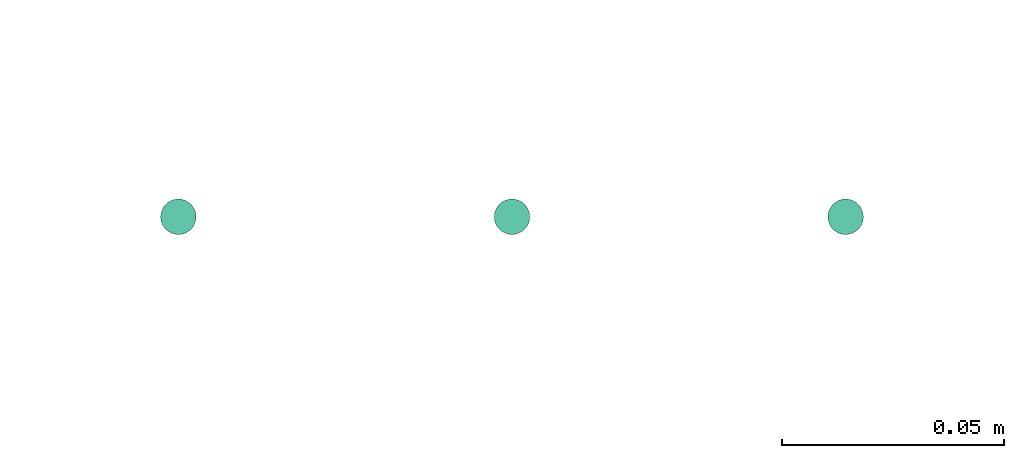
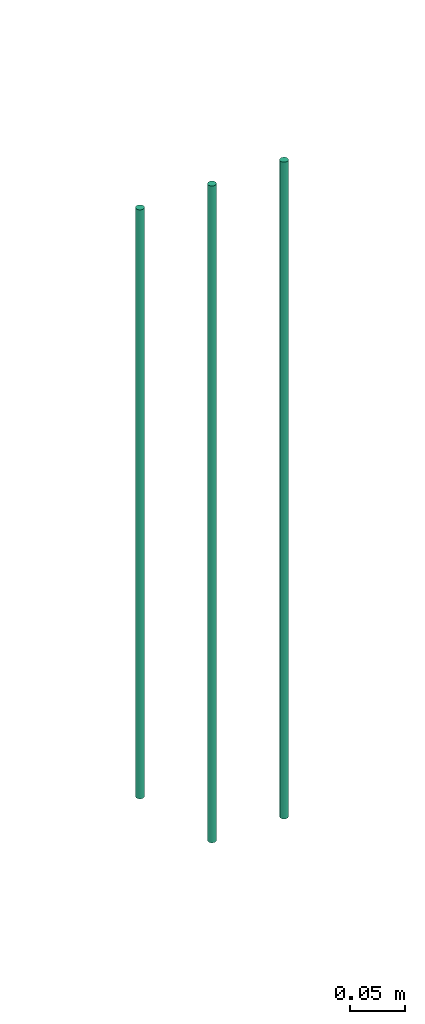
# One storey, part 36 of 65: 3 flow segments.
"""IFC2X3 building model written with IfcOpenShell, lengths in millimetres."""

from ifc_helpers import new_model, entity, si_unit, converted_unit, derived_unit, direction, frame, origin, origin_2d_with_axis, place, context, subcontext, project, spatial, circle, extrude, type_object, element, save


model = new_model("IFC2X3")

# Units and contexts
model_context = context("Model", 3, precision=0.01, world=origin(), true_north=direction((6.12303176911189e-17, 1.0)))
body_context = subcontext(model_context, "Body", "Model", "MODEL_VIEW")
ifc_project = project(units=[si_unit("LENGTHUNIT", "METRE", prefix="MILLI"), si_unit("AREAUNIT", "SQUARE_METRE"), si_unit("VOLUMEUNIT", "CUBIC_METRE"), converted_unit("PLANEANGLEUNIT", "DEGREE", entity("IfcRatioMeasure", 0.0174532925199433), si_unit("PLANEANGLEUNIT", "RADIAN"), dimensions=[0, 0, 0, 0, 0, 0, 0]), si_unit("MASSUNIT", "GRAM", prefix="KILO"), derived_unit("MASSDENSITYUNIT", [(si_unit("MASSUNIT", "GRAM", prefix="KILO"), 1), (si_unit("LENGTHUNIT", "METRE"), -3)]), derived_unit("MOMENTOFINERTIAUNIT", [(si_unit("LENGTHUNIT", "METRE"), 4)]), si_unit("TIMEUNIT", "SECOND"), si_unit("FREQUENCYUNIT", "HERTZ"), si_unit("THERMODYNAMICTEMPERATUREUNIT", "DEGREE_CELSIUS"), derived_unit("THERMALTRANSMITTANCEUNIT", [(si_unit("MASSUNIT", "GRAM", prefix="KILO"), 1), (si_unit("THERMODYNAMICTEMPERATUREUNIT", "KELVIN"), -1), (si_unit("TIMEUNIT", "SECOND"), -3)]), derived_unit("VOLUMETRICFLOWRATEUNIT", [(si_unit("LENGTHUNIT", "METRE"), 3), (si_unit("TIMEUNIT", "SECOND"), -1)]), derived_unit("MASSFLOWRATEUNIT", [(si_unit("MASSUNIT", "GRAM", prefix="KILO"), 1), (si_unit("TIMEUNIT", "SECOND"), -1)]), derived_unit("ROTATIONALFREQUENCYUNIT", [(si_unit("TIMEUNIT", "SECOND"), -1)]), si_unit("ELECTRICCURRENTUNIT", "AMPERE"), si_unit("ELECTRICVOLTAGEUNIT", "VOLT"), si_unit("POWERUNIT", "WATT"), si_unit("FORCEUNIT", "NEWTON", prefix="KILO"), si_unit("ILLUMINANCEUNIT", "LUX"), si_unit("LUMINOUSFLUXUNIT", "LUMEN"), si_unit("LUMINOUSINTENSITYUNIT", "CANDELA"), derived_unit("USERDEFINED", [(si_unit("MASSUNIT", "GRAM", prefix="KILO"), -1), (si_unit("LENGTHUNIT", "METRE"), -2), (si_unit("TIMEUNIT", "SECOND"), 3), (si_unit("LUMINOUSFLUXUNIT", "LUMEN"), 1)]), derived_unit("LINEARVELOCITYUNIT", [(si_unit("LENGTHUNIT", "METRE"), 1), (si_unit("TIMEUNIT", "SECOND"), -1)]), si_unit("PRESSUREUNIT", "PASCAL"), derived_unit("USERDEFINED", [(si_unit("LENGTHUNIT", "METRE"), -2), (si_unit("MASSUNIT", "GRAM", prefix="KILO"), 1), (si_unit("TIMEUNIT", "SECOND"), -2)]), derived_unit("LINEARFORCEUNIT", [(si_unit("MASSUNIT", "GRAM", prefix="KILO"), 1), (si_unit("LENGTHUNIT", "METRE"), 1), (si_unit("TIMEUNIT", "SECOND"), -2), (si_unit("LENGTHUNIT", "METRE"), -1)]), derived_unit("PLANARFORCEUNIT", [(si_unit("MASSUNIT", "GRAM", prefix="KILO"), 1), (si_unit("LENGTHUNIT", "METRE"), 1), (si_unit("TIMEUNIT", "SECOND"), -2), (si_unit("LENGTHUNIT", "METRE"), -2)])], contexts=[model_context])

# Site, building, storey
site_placement = place(None, frame((0.0, -0.00077364408347762, 0.0)))
site = spatial("IfcSite", under=ifc_project, at=site_placement, CompositionType="ELEMENT")
building_placement = place(site_placement, origin())
building = spatial("IfcBuilding", under=site, at=building_placement, CompositionType="ELEMENT")
storey_placement = place(building_placement, frame((0.0, 0.0, 19800.0)))
storey = spatial("IfcBuildingStorey", under=building, at=storey_placement, CompositionType="ELEMENT", Elevation=19800.0)

# Flow segments
pipe_segment_type = type_object("IfcPipeSegmentType", PredefinedType="NOTDEFINED")
flow_segment_placement = place(storey_placement, frame((37971.440385921, 16317.65509256, -12965.4069643775)))
element("IfcFlowSegment", 1, at=flow_segment_placement, inside=storey, type_object=pipe_segment_type, context=body_context, shape_type="SweptSolid", body=[
    extrude(circle(Radius=4.0, at=origin_2d_with_axis()), frame((5.59527223591499, 5.59527223591499, 0.0), z_axis=(0.0, 0.0, 1.0), x_axis=(-1.0, 0.0, 0.0)), (0.0, 0.0, 1.0), 648.406964377514),
])
for number, where in (
    (2, (38046.440385921, 16317.65509256, -13040.0)),
    (3, (38121.440385921, 16317.65509256, -13040.0)),
):
    element("IfcFlowSegment", number, at=place(storey_placement, frame(where)), inside=storey, type_object=pipe_segment_type, context=body_context, shape_type="SweptSolid", body=[
        extrude(circle(Radius=4.0, at=origin_2d_with_axis()), frame((5.59527223591499, 5.59527223591499, 0.0), z_axis=(0.0, 0.0, 1.0), x_axis=(-1.0, 0.0, 0.0)), (0.0, 0.0, 1.0), 723.000000000005),
    ])

save(model, "model.ifc")
